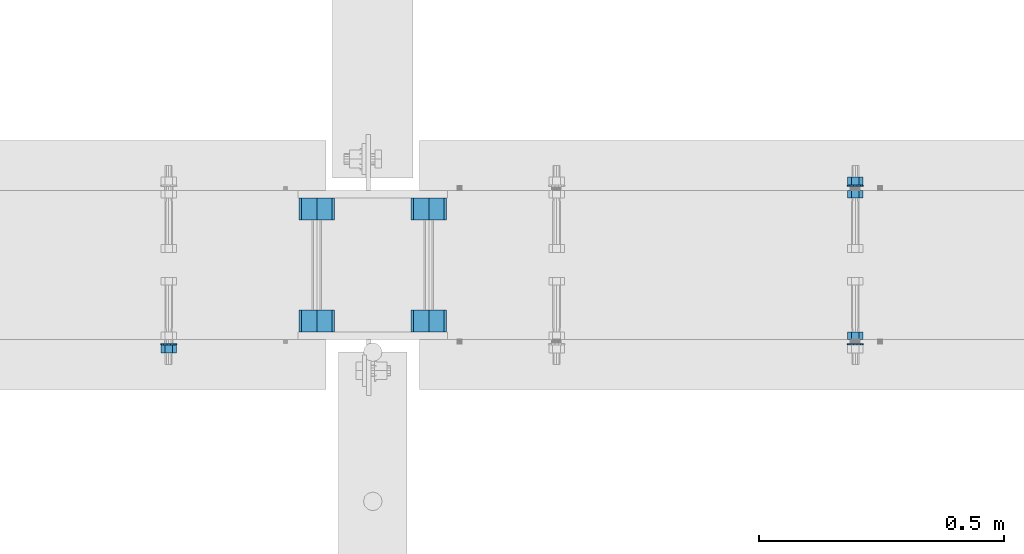
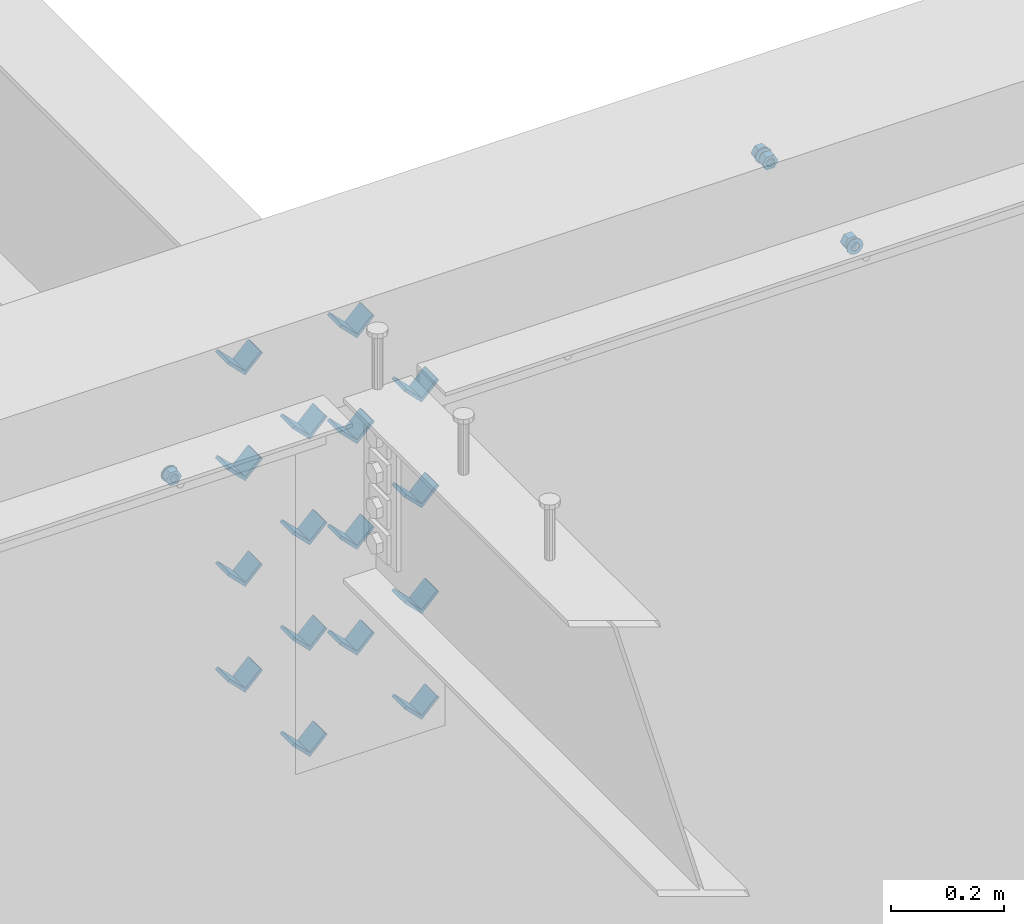
# One storey, part 604 of 975: 23 beams.
"""IFC2X3 building model written with IfcOpenShell, lengths in millimetres."""

from ifc_helpers import new_model, si_unit, frame, origin_with_axes, place, context, subcontext, project, spatial, faceted_brep, material, type_object, element, save


model = new_model("IFC2X3")

# Units and contexts
model_context = context("Model", 3, precision=1e-05, world=origin_with_axes())
body_context = subcontext(model_context, "Body", "Model", "MODEL_VIEW")
ifc_project = project(units=[si_unit("LENGTHUNIT", "METRE", prefix="MILLI"), si_unit("AREAUNIT", "SQUARE_METRE"), si_unit("VOLUMEUNIT", "CUBIC_METRE"), si_unit("MASSUNIT", "GRAM", prefix="KILO"), si_unit("TIMEUNIT", "SECOND"), si_unit("PLANEANGLEUNIT", "RADIAN"), si_unit("SOLIDANGLEUNIT", "STERADIAN"), si_unit("THERMODYNAMICTEMPERATUREUNIT", "DEGREE_CELSIUS"), si_unit("LUMINOUSINTENSITYUNIT", "LUMEN")], contexts=[model_context])

# Site, building, storey
site_placement = place(None, origin_with_axes())
site = spatial("IfcSite", under=ifc_project, at=site_placement, CompositionType="ELEMENT")
building_placement = place(site_placement, origin_with_axes())
building = spatial("IfcBuilding", under=site, at=building_placement, Name="Undefined", CompositionType="ELEMENT")
storey_placement = place(building_placement, origin_with_axes())
storey = spatial("IfcBuildingStorey", under=building, at=storey_placement, Name="Undefined", CompositionType="ELEMENT", Elevation=0.0)

# Beams
ifc_material = material(Name="STEEL/A36")
beam_type_1 = type_object("IfcBeamType", Name="L2X2X1/4", PredefinedType="NOTDEFINED")
for number, where, z_axis, x_axis, name in (
    (1, (4176.18387741957, 20459.6337290899, 3417.06996517217), (-0.707106781186557, 0.0, 0.707106781186538), (0.0, 1.0, 0.0), "ANGLE"),
    (2, (4404.78387741958, 20459.6337290899, 3417.06996517217), (-0.707106781186557, 0.0, 0.707106781186538), (0.0, 1.0, 0.0), "ANGLE"),
    (3, (4176.18387741957, 20688.3662709101, 3417.06996517217), (-0.707106781186557, 0.0, 0.707106781186538), (0.0, 1.0, 0.0), "ANGLE"),
    (4, (4404.78387741958, 20688.3662709101, 3417.06996517217), (-0.707106781186557, 0.0, 0.707106781186538), (0.0, 1.0, 0.0), "ANGLE"),
    (5, (4176.18387741957, 20459.6337290899, 3645.66996517217), (-0.707106781186557, 0.0, 0.707106781186538), (0.0, 1.0, 0.0), "ANGLE"),
    (6, (4404.78387741958, 20459.6337290899, 3645.66996517217), (-0.707106781186557, 0.0, 0.707106781186538), (0.0, 1.0, 0.0), "ANGLE"),
    (7, (4176.18387741957, 20688.3662709101, 3645.66996517217), (-0.707106781186557, 0.0, 0.707106781186538), (0.0, 1.0, 0.0), "ANGLE"),
    (8, (4404.78387741958, 20688.3662709101, 3645.66996517217), (-0.707106781186557, 0.0, 0.707106781186538), (0.0, 1.0, 0.0), "ANGLE"),
    (9, (4176.18387741845, 20459.6337290899, 3188.4699651707), (-0.707106781186557, 0.0, 0.707106781186538), (0.0, 1.0, 0.0), "ANGLE"),
    (10, (4176.18387741957, 20459.6337290899, 3874.26996517217), (-0.707106781186557, 0.0, 0.707106781186538), (0.0, 1.0, 0.0), "ANGLE"),
    (11, (4404.78387741845, 20459.6337290899, 3188.4699651707), (-0.707106781186557, 0.0, 0.707106781186538), (0.0, 1.0, 0.0), "ANGLE"),
    (12, (4404.78387741958, 20459.6337290899, 3874.26996517217), (-0.707106781186557, 0.0, 0.707106781186538), (0.0, 1.0, 0.0), "ANGLE"),
    (13, (4176.18387741845, 20688.3662709101, 3188.4699651707), (-0.707106781186557, 0.0, 0.707106781186538), (0.0, 1.0, 0.0), "ANGLE"),
    (14, (4176.18387741957, 20688.3662709101, 3874.26996517217), (-0.707106781186557, 0.0, 0.707106781186538), (0.0, 1.0, 0.0), "ANGLE"),
    (15, (4404.78387741845, 20688.3662709101, 3188.4699651707), (-0.707106781186557, 0.0, 0.707106781186538), (0.0, 1.0, 0.0), "ANGLE"),
    (16, (4404.78387741958, 20688.3662709101, 3874.26996517217), (-0.707106781186557, 0.0, 0.707106781186538), (0.0, 1.0, 0.0), "ANGLE"),
):
    element("IfcBeam", number, at=place(storey_placement, frame(where, z_axis=z_axis, x_axis=x_axis)), inside=storey, type_object=beam_type_1, material=ifc_material, Name=name, ObjectType="L2X2X1/4", context=body_context, shape_type="Brep", body=[
        faceted_brep([(0.0, 25.3999999999724, -25.4000000000342), (0.0, 25.400000000016, 25.4000000000196), (44.4499999999971, 25.4000000000033, 25.4000000000051), (44.4499999999971, 25.4000000000033, -25.4000000000024), (3.27418092638254e-11, 19.0500000000002, 25.4000000000269), (44.4499999999971, 19.0500000000011, 25.400000000006), (-2.5465851649642e-11, 19.0500000000002, -19.0500000000211), (44.4499999999971, 19.0500000000011, -19.050000000002), (-2.5465851649642e-11, -25.3999999999996, -19.0500000000211), (44.4499999999971, -25.4000000000069, -19.0500000000038), (0.0, -25.400000000016, -25.4000000000196), (44.4499999999971, -25.4000000000069, -25.4000000000033)], [[[0, 1, 2, 3]], [[1, 4, 5, 2]], [[4, 6, 7, 5]], [[6, 8, 9, 7]], [[8, 10, 11, 9]], [[10, 0, 3, 11]], [[5, 7, 9, 11, 3, 2]], [[10, 8, 6, 4, 1, 0]]]),
    ])
beam_type_2 = type_object("IfcBeamType", Name="5/8_HEAVY_HEX_NUT", PredefinedType="NOTDEFINED")
beam_1_placement = place(storey_placement, frame((5275.26259380676, 20443.825, 3886.2), z_axis=(0.0, 0.0, -1.0), x_axis=(0.0, 1.0, 0.0)))
element("IfcBeam", 17, at=beam_1_placement, inside=storey, type_object=beam_type_2, material=ifc_material, Name="NUT", ObjectType="5/8_HEAVY_HEX_NUT", context=body_context, shape_type="Brep", body=[
    faceted_brep([(-1.09139364212751e-11, -15.8800001144436, -2.72848410531878e-12), (1.45519152283669e-11, -7.94000005722046, -13.7500000000036), (15.8750000000146, -7.94000005722137, -13.7500000000045), (15.8749999999891, -15.8800001144446, -2.72848410531878e-12), (2.91038304567337e-11, 7.94000005722319, -13.7500000000027), (15.8750000000291, 7.94000005722319, -13.7500000000027), (2.18278728425503e-11, 15.8800001144436, 9.09494701772928e-13), (15.8750000000218, 15.8800001144427, 9.09494701772928e-13), (-7.27595761418343e-12, 7.94000005722046, 13.7500000000027), (15.8749999999927, 7.94000005722046, 13.7500000000027), (-2.18278728425503e-11, -7.94000005722228, 13.7500000000009), (15.8749999999782, -7.94000005722319, 13.7500000000009), (-7.27595761418343e-12, 0.0, 8.72999954223724), (0.0, 3.78780484388062, 7.86545780435881), (15.875, 3.78780484387971, 7.86545780435881), (15.8749999999927, -9.09494701772928e-13, 8.72999954223724), (7.27595761418343e-12, 6.82538848405238, 5.44306568481716), (15.8750000000073, 6.82538848405238, 5.44306568481716), (1.09139364212751e-11, 8.51112022706275, 1.94260765157742), (15.8750000000109, 8.51112022706093, 1.94260765157651), (1.45519152283669e-11, 8.51112022706184, -1.94260765157651), (15.8750000000146, 8.51112022706184, -1.94260765157651), (2.18278728425503e-11, 6.8253884840542, -5.44306568481716), (15.8750000000218, 6.82538848405238, -5.44306568481716), (1.81898940354586e-11, 3.78780484388153, -7.86545780435881), (15.8750000000182, 3.78780484388062, -7.86545780435881), (1.81898940354586e-11, 9.09494701772928e-13, -8.72999954223997), (15.8750000000182, 9.09494701772928e-13, -8.72999954223997), (1.09139364212751e-11, -3.78780484387971, -7.86545780436063), (15.8750000000109, -3.78780484388062, -7.86545780436063), (3.63797880709171e-12, -6.82538848405238, -5.44306568481807), (15.8750000000036, -6.82538848405329, -5.44306568481807), (0.0, -8.51112022706184, -1.94260765157833), (15.875, -8.51112022706184, -1.94260765157833), (-7.27595761418343e-12, -8.51112022706184, 1.9426076515756), (15.8749999999927, -8.51112022706275, 1.9426076515756), (-1.09139364212751e-11, -6.82538848405329, 5.44306568481534), (15.8749999999927, -6.8253884840542, 5.44306568481534), (-7.27595761418343e-12, -3.78780484388062, 7.8654578043579), (15.8749999999927, -3.78780484388153, 7.8654578043579)], [[[0, 1, 2, 3]], [[1, 4, 5, 2]], [[4, 6, 7, 5]], [[6, 8, 9, 7]], [[8, 10, 11, 9]], [[10, 0, 3, 11]], [[12, 13, 14, 15]], [[13, 16, 17, 14]], [[16, 18, 19, 17]], [[18, 20, 21, 19]], [[20, 22, 23, 21]], [[22, 24, 25, 23]], [[24, 26, 27, 25]], [[26, 28, 29, 27]], [[28, 30, 31, 29]], [[30, 32, 33, 31]], [[32, 34, 35, 33]], [[34, 36, 37, 35]], [[36, 38, 39, 37]], [[38, 12, 15, 39]], [[5, 7, 9, 11, 3, 2], [17, 19, 21, 23, 25, 27, 29, 31, 33, 35, 37, 39, 15, 14]], [[10, 8, 6, 4, 1, 0], [38, 36, 34, 32, 30, 28, 26, 24, 22, 20, 18, 16, 13, 12]]]),
])
beam_2_placement = place(storey_placement, frame((5275.26259380676, 20748.6249996637, 3886.2), z_axis=(0.0, 0.0, 1.0), x_axis=(0.0, -1.0, 0.0)))
element("IfcBeam", 18, at=beam_2_placement, inside=storey, type_object=beam_type_2, material=ifc_material, Name="NUT", ObjectType="5/8_HEAVY_HEX_NUT", context=body_context, shape_type="Brep", body=[
    faceted_brep([(-1.09139364212751e-11, -15.8800001144436, -2.72848410531878e-12), (1.45519152283669e-11, -7.94000005722046, -13.7500000000036), (15.8750000000146, -7.94000005722137, -13.7500000000045), (15.8749999999891, -15.8800001144446, -2.72848410531878e-12), (2.91038304567337e-11, 7.94000005722319, -13.7500000000027), (15.8750000000291, 7.94000005722319, -13.7500000000027), (2.18278728425503e-11, 15.8800001144436, 9.09494701772928e-13), (15.8750000000218, 15.8800001144427, 9.09494701772928e-13), (-7.27595761418343e-12, 7.94000005722046, 13.7500000000027), (15.8749999999927, 7.94000005722046, 13.7500000000027), (-2.18278728425503e-11, -7.94000005722228, 13.7500000000009), (15.8749999999782, -7.94000005722319, 13.7500000000009), (-7.27595761418343e-12, 0.0, 8.72999954223724), (0.0, 3.78780484388062, 7.86545780435881), (15.875, 3.78780484387971, 7.86545780435881), (15.8749999999927, -9.09494701772928e-13, 8.72999954223724), (7.27595761418343e-12, 6.82538848405238, 5.44306568481716), (15.8750000000073, 6.82538848405238, 5.44306568481716), (1.09139364212751e-11, 8.51112022706275, 1.94260765157742), (15.8750000000109, 8.51112022706093, 1.94260765157651), (1.45519152283669e-11, 8.51112022706184, -1.94260765157651), (15.8750000000146, 8.51112022706184, -1.94260765157651), (2.18278728425503e-11, 6.8253884840542, -5.44306568481716), (15.8750000000218, 6.82538848405238, -5.44306568481716), (1.81898940354586e-11, 3.78780484388153, -7.86545780435881), (15.8750000000182, 3.78780484388062, -7.86545780435881), (1.81898940354586e-11, 9.09494701772928e-13, -8.72999954223997), (15.8750000000182, 9.09494701772928e-13, -8.72999954223997), (1.09139364212751e-11, -3.78780484387971, -7.86545780436063), (15.8750000000109, -3.78780484388062, -7.86545780436063), (3.63797880709171e-12, -6.82538848405238, -5.44306568481807), (15.8750000000036, -6.82538848405329, -5.44306568481807), (0.0, -8.51112022706184, -1.94260765157833), (15.875, -8.51112022706184, -1.94260765157833), (-7.27595761418343e-12, -8.51112022706184, 1.9426076515756), (15.8749999999927, -8.51112022706275, 1.9426076515756), (-1.09139364212751e-11, -6.82538848405329, 5.44306568481534), (15.8749999999927, -6.8253884840542, 5.44306568481534), (-7.27595761418343e-12, -3.78780484388062, 7.8654578043579), (15.8749999999927, -3.78780484388153, 7.8654578043579)], [[[0, 1, 2, 3]], [[1, 4, 5, 2]], [[4, 6, 7, 5]], [[6, 8, 9, 7]], [[8, 10, 11, 9]], [[10, 0, 3, 11]], [[12, 13, 14, 15]], [[13, 16, 17, 14]], [[16, 18, 19, 17]], [[18, 20, 21, 19]], [[20, 22, 23, 21]], [[22, 24, 25, 23]], [[24, 26, 27, 25]], [[26, 28, 29, 27]], [[28, 30, 31, 29]], [[30, 32, 33, 31]], [[32, 34, 35, 33]], [[34, 36, 37, 35]], [[36, 38, 39, 37]], [[38, 12, 15, 39]], [[5, 7, 9, 11, 3, 2], [17, 19, 21, 23, 25, 27, 29, 31, 33, 35, 37, 39, 15, 14]], [[10, 8, 6, 4, 1, 0], [38, 36, 34, 32, 30, 28, 26, 24, 22, 20, 18, 16, 13, 12]]]),
])
beam_3_placement = place(storey_placement, frame((5275.26259380678, 20775.6125, 3886.2), z_axis=(0.0, 0.0, 1.0), x_axis=(0.0, -1.0, 0.0)))
element("IfcBeam", 19, at=beam_3_placement, inside=storey, type_object=beam_type_2, material=ifc_material, Name="NUT", ObjectType="5/8_HEAVY_HEX_NUT", context=body_context, shape_type="Brep", body=[
    faceted_brep([(-1.09139364212751e-11, -15.8800001144436, -2.72848410531878e-12), (1.45519152283669e-11, -7.94000005722046, -13.7500000000036), (15.8750000000146, -7.94000005722137, -13.7500000000045), (15.8749999999891, -15.8800001144446, -2.72848410531878e-12), (2.91038304567337e-11, 7.94000005722319, -13.7500000000027), (15.8750000000291, 7.94000005722319, -13.7500000000027), (2.18278728425503e-11, 15.8800001144436, 9.09494701772928e-13), (15.8750000000218, 15.8800001144427, 9.09494701772928e-13), (-7.27595761418343e-12, 7.94000005722046, 13.7500000000027), (15.8749999999927, 7.94000005722046, 13.7500000000027), (-2.18278728425503e-11, -7.94000005722228, 13.7500000000009), (15.8749999999782, -7.94000005722319, 13.7500000000009), (-7.27595761418343e-12, 0.0, 8.72999954223724), (0.0, 3.78780484388062, 7.86545780435881), (15.875, 3.78780484387971, 7.86545780435881), (15.8749999999927, -9.09494701772928e-13, 8.72999954223724), (7.27595761418343e-12, 6.82538848405238, 5.44306568481716), (15.8750000000073, 6.82538848405238, 5.44306568481716), (1.09139364212751e-11, 8.51112022706275, 1.94260765157742), (15.8750000000109, 8.51112022706093, 1.94260765157651), (1.45519152283669e-11, 8.51112022706184, -1.94260765157651), (15.8750000000146, 8.51112022706184, -1.94260765157651), (2.18278728425503e-11, 6.8253884840542, -5.44306568481716), (15.8750000000218, 6.82538848405238, -5.44306568481716), (1.81898940354586e-11, 3.78780484388153, -7.86545780435881), (15.8750000000182, 3.78780484388062, -7.86545780435881), (1.81898940354586e-11, 9.09494701772928e-13, -8.72999954223997), (15.8750000000182, 9.09494701772928e-13, -8.72999954223997), (1.09139364212751e-11, -3.78780484387971, -7.86545780436063), (15.8750000000109, -3.78780484388062, -7.86545780436063), (3.63797880709171e-12, -6.82538848405238, -5.44306568481807), (15.8750000000036, -6.82538848405329, -5.44306568481807), (0.0, -8.51112022706184, -1.94260765157833), (15.875, -8.51112022706184, -1.94260765157833), (-7.27595761418343e-12, -8.51112022706184, 1.9426076515756), (15.8749999999927, -8.51112022706275, 1.9426076515756), (-1.09139364212751e-11, -6.82538848405329, 5.44306568481534), (15.8749999999927, -6.8253884840542, 5.44306568481534), (-7.27595761418343e-12, -3.78780484388062, 7.8654578043579), (15.8749999999927, -3.78780484388153, 7.8654578043579)], [[[0, 1, 2, 3]], [[1, 4, 5, 2]], [[4, 6, 7, 5]], [[6, 8, 9, 7]], [[8, 10, 11, 9]], [[10, 0, 3, 11]], [[12, 13, 14, 15]], [[13, 16, 17, 14]], [[16, 18, 19, 17]], [[18, 20, 21, 19]], [[20, 22, 23, 21]], [[22, 24, 25, 23]], [[24, 26, 27, 25]], [[26, 28, 29, 27]], [[28, 30, 31, 29]], [[30, 32, 33, 31]], [[32, 34, 35, 33]], [[34, 36, 37, 35]], [[36, 38, 39, 37]], [[38, 12, 15, 39]], [[5, 7, 9, 11, 3, 2], [17, 19, 21, 23, 25, 27, 29, 31, 33, 35, 37, 39, 15, 14]], [[10, 8, 6, 4, 1, 0], [38, 36, 34, 32, 30, 28, 26, 24, 22, 20, 18, 16, 13, 12]]]),
])
beam_4_placement = place(storey_placement, frame((3874.02920478859, 20416.8375, 3886.2), z_axis=(0.0, 0.0, 1.0), x_axis=(0.0, 1.0, 0.0)))
element("IfcBeam", 20, at=beam_4_placement, inside=storey, type_object=beam_type_2, material=ifc_material, Name="NUT", ObjectType="5/8_HEAVY_HEX_NUT", context=body_context, shape_type="Brep", body=[
    faceted_brep([(-1.09139364212751e-11, -15.8800001144436, -2.72848410531878e-12), (1.45519152283669e-11, -7.94000005722046, -13.7500000000036), (15.8750000000146, -7.94000005722137, -13.7500000000045), (15.8749999999891, -15.8800001144446, -2.72848410531878e-12), (2.91038304567337e-11, 7.94000005722319, -13.7500000000027), (15.8750000000291, 7.94000005722319, -13.7500000000027), (2.18278728425503e-11, 15.8800001144436, 9.09494701772928e-13), (15.8750000000218, 15.8800001144427, 9.09494701772928e-13), (-7.27595761418343e-12, 7.94000005722046, 13.7500000000027), (15.8749999999927, 7.94000005722046, 13.7500000000027), (-2.18278728425503e-11, -7.94000005722228, 13.7500000000009), (15.8749999999782, -7.94000005722319, 13.7500000000009), (-7.27595761418343e-12, 0.0, 8.72999954223724), (0.0, 3.78780484388062, 7.86545780435881), (15.875, 3.78780484387971, 7.86545780435881), (15.8749999999927, -9.09494701772928e-13, 8.72999954223724), (7.27595761418343e-12, 6.82538848405238, 5.44306568481716), (15.8750000000073, 6.82538848405238, 5.44306568481716), (1.09139364212751e-11, 8.51112022706275, 1.94260765157742), (15.8750000000109, 8.51112022706093, 1.94260765157651), (1.45519152283669e-11, 8.51112022706184, -1.94260765157651), (15.8750000000146, 8.51112022706184, -1.94260765157651), (2.18278728425503e-11, 6.8253884840542, -5.44306568481716), (15.8750000000218, 6.82538848405238, -5.44306568481716), (1.81898940354586e-11, 3.78780484388153, -7.86545780435881), (15.8750000000182, 3.78780484388062, -7.86545780435881), (1.81898940354586e-11, 9.09494701772928e-13, -8.72999954223997), (15.8750000000182, 9.09494701772928e-13, -8.72999954223997), (1.09139364212751e-11, -3.78780484387971, -7.86545780436063), (15.8750000000109, -3.78780484388062, -7.86545780436063), (3.63797880709171e-12, -6.82538848405238, -5.44306568481807), (15.8750000000036, -6.82538848405329, -5.44306568481807), (0.0, -8.51112022706184, -1.94260765157833), (15.875, -8.51112022706184, -1.94260765157833), (-7.27595761418343e-12, -8.51112022706184, 1.9426076515756), (15.8749999999927, -8.51112022706275, 1.9426076515756), (-1.09139364212751e-11, -6.82538848405329, 5.44306568481534), (15.8749999999927, -6.8253884840542, 5.44306568481534), (-7.27595761418343e-12, -3.78780484388062, 7.8654578043579), (15.8749999999927, -3.78780484388153, 7.8654578043579)], [[[0, 1, 2, 3]], [[1, 4, 5, 2]], [[4, 6, 7, 5]], [[6, 8, 9, 7]], [[8, 10, 11, 9]], [[10, 0, 3, 11]], [[12, 13, 14, 15]], [[13, 16, 17, 14]], [[16, 18, 19, 17]], [[18, 20, 21, 19]], [[20, 22, 23, 21]], [[22, 24, 25, 23]], [[24, 26, 27, 25]], [[26, 28, 29, 27]], [[28, 30, 31, 29]], [[30, 32, 33, 31]], [[32, 34, 35, 33]], [[34, 36, 37, 35]], [[36, 38, 39, 37]], [[38, 12, 15, 39]], [[5, 7, 9, 11, 3, 2], [17, 19, 21, 23, 25, 27, 29, 31, 33, 35, 37, 39, 15, 14]], [[10, 8, 6, 4, 1, 0], [38, 36, 34, 32, 30, 28, 26, 24, 22, 20, 18, 16, 13, 12]]]),
])
beam_type_3 = type_object("IfcBeamType", Name="5/8_WASHER", PredefinedType="NOTDEFINED")
beam_5_placement = place(storey_placement, frame((5275.26259380682, 20759.7375, 3886.2), z_axis=(0.0, 0.0, 1.0), x_axis=(0.0, -1.0, 0.0)))
element("IfcBeam", 21, at=beam_5_placement, inside=storey, type_object=beam_type_3, material=ifc_material, Name="WASHER", ObjectType="5/8_WASHER", context=body_context, shape_type="Brep", body=[
    faceted_brep([(1.09139364212751e-11, -16.670000076293, -2.72848410531878e-12), (2.18278728425503e-11, -15.0191510966704, -7.23284196419536), (3.1750000000211, -15.0191510966711, -7.23284196419627), (3.17500000001019, -16.6700000762937, -1.81898940354586e-12), (2.91038304567337e-11, -10.3935750445523, -13.0331308723944), (3.17500000002838, -10.3935750445526, -13.0331308723953), (2.91038304567337e-11, -3.70942398602756, -16.2520483704566), (3.17500000002838, -3.70942398602779, -16.2520483704566), (2.5465851649642e-11, 3.70942398602961, -16.2520483704557), (3.17500000002474, 3.70942398602961, -16.2520483704566), (1.45519152283669e-11, 10.3935750445542, -13.0331308723935), (3.17500000001382, 10.3935750445537, -13.0331308723944), (0.0, 15.0191510966717, -7.23284196419354), (3.17499999999927, 15.0191510966713, -7.23284196419354), (-7.27595761418343e-12, 16.6700000762933, 0.0), (3.174999999992, 16.6700000762928, -9.09494701772928e-13), (-1.81898940354586e-11, 15.0191510966706, 7.23284196419354), (3.17499999998108, 15.0191510966704, 7.23284196419354), (-2.5465851649642e-11, 10.3935750445519, 13.0331308723926), (3.17499999997381, 10.3935750445517, 13.0331308723926), (-2.5465851649642e-11, 3.70942398602733, 16.2520483704538), (3.17499999997381, 3.7094239860271, 16.2520483704529), (-2.18278728425503e-11, -3.70942398602983, 16.2520483704529), (3.17499999997744, -3.70942398603006, 16.2520483704538), (-1.09139364212751e-11, -10.3935750445542, 13.0331308723908), (3.17499999998836, -10.3935750445544, 13.0331308723908), (0.0, -15.0191510966717, 7.23284196419172), (3.17499999999927, -15.019151096672, 7.23284196419081), (-7.27595761418343e-12, 0.0, 8.72999954223724), (0.0, 3.78780484388062, 7.86545780435881), (3.17499999998472, 3.78780484387903, 7.86545780435699), (3.17499999998836, -9.09494701772928e-13, 8.72999954223542), (7.27595761418343e-12, 6.82538848405238, 5.44306568481716), (3.17499999998836, 6.82538848405102, 5.44306568481534), (1.09139364212751e-11, 8.51112022706275, 1.94260765157742), (3.174999999992, 8.51112022705979, 1.94260765157651), (1.45519152283669e-11, 8.51112022706184, -1.94260765157651), (3.17499999999563, 8.51112022706025, -1.94260765157742), (2.18278728425503e-11, 6.8253884840542, -5.44306568481716), (3.17500000000655, 6.8253884840517, -5.44306568481807), (1.81898940354586e-11, 3.78780484388153, -7.86545780435881), (3.17500000001019, 3.78780484388017, -7.86545780435972), (1.81898940354586e-11, 9.09494701772928e-13, -8.72999954223997), (3.17500000001382, 6.82121026329696e-13, -8.72999954223997), (1.09139364212751e-11, -3.78780484387971, -7.86545780436063), (3.17500000001382, -3.78780484387994, -7.86545780436063), (3.63797880709171e-12, -6.82538848405238, -5.44306568481807), (3.17500000001019, -6.82538848405147, -5.44306568481898), (0.0, -8.51112022706184, -1.94260765157833), (3.17500000001019, -8.5111202270607, -1.94260765157924), (-7.27595761418343e-12, -8.51112022706184, 1.9426076515756), (3.17500000000291, -8.51112022706093, 1.94260765157469), (-1.09139364212751e-11, -6.82538848405329, 5.44306568481534), (3.17499999999563, -6.82538848405238, 5.44306568481534), (-7.27595761418343e-12, -3.78780484388062, 7.8654578043579), (3.174999999992, -3.78780484388085, 7.86545780435699)], [[[0, 1, 2, 3]], [[1, 4, 5, 2]], [[4, 6, 7, 5]], [[6, 8, 9, 7]], [[8, 10, 11, 9]], [[10, 12, 13, 11]], [[12, 14, 15, 13]], [[14, 16, 17, 15]], [[16, 18, 19, 17]], [[18, 20, 21, 19]], [[20, 22, 23, 21]], [[22, 24, 25, 23]], [[24, 26, 27, 25]], [[26, 0, 3, 27]], [[28, 29, 30, 31]], [[29, 32, 33, 30]], [[32, 34, 35, 33]], [[34, 36, 37, 35]], [[36, 38, 39, 37]], [[38, 40, 41, 39]], [[40, 42, 43, 41]], [[42, 44, 45, 43]], [[44, 46, 47, 45]], [[46, 48, 49, 47]], [[48, 50, 51, 49]], [[50, 52, 53, 51]], [[52, 54, 55, 53]], [[54, 28, 31, 55]], [[5, 7, 9, 11, 13, 15, 17, 19, 21, 23, 25, 27, 3, 2], [33, 35, 37, 39, 41, 43, 45, 47, 49, 51, 53, 55, 31, 30]], [[26, 24, 22, 20, 18, 16, 14, 12, 10, 8, 6, 4, 1, 0], [54, 52, 50, 48, 46, 44, 42, 40, 38, 36, 34, 32, 29, 28]]]),
])
beam_6_placement = place(storey_placement, frame((5275.26259380682, 20432.7125, 3886.2), z_axis=(0.0, 0.0, -1.0), x_axis=(0.0, 1.0, 0.0)))
element("IfcBeam", 22, at=beam_6_placement, inside=storey, type_object=beam_type_3, material=ifc_material, Name="WASHER", ObjectType="5/8_WASHER", context=body_context, shape_type="Brep", body=[
    faceted_brep([(1.09139364212751e-11, -16.670000076293, -2.72848410531878e-12), (2.18278728425503e-11, -15.0191510966704, -7.23284196419536), (3.1750000000211, -15.0191510966711, -7.23284196419627), (3.17500000001019, -16.6700000762937, -1.81898940354586e-12), (2.91038304567337e-11, -10.3935750445523, -13.0331308723944), (3.17500000002838, -10.3935750445526, -13.0331308723953), (2.91038304567337e-11, -3.70942398602756, -16.2520483704566), (3.17500000002838, -3.70942398602779, -16.2520483704566), (2.5465851649642e-11, 3.70942398602961, -16.2520483704557), (3.17500000002474, 3.70942398602961, -16.2520483704566), (1.45519152283669e-11, 10.3935750445542, -13.0331308723935), (3.17500000001382, 10.3935750445537, -13.0331308723944), (0.0, 15.0191510966717, -7.23284196419354), (3.17499999999927, 15.0191510966713, -7.23284196419354), (-7.27595761418343e-12, 16.6700000762933, 0.0), (3.174999999992, 16.6700000762928, -9.09494701772928e-13), (-1.81898940354586e-11, 15.0191510966706, 7.23284196419354), (3.17499999998108, 15.0191510966704, 7.23284196419354), (-2.5465851649642e-11, 10.3935750445519, 13.0331308723926), (3.17499999997381, 10.3935750445517, 13.0331308723926), (-2.5465851649642e-11, 3.70942398602733, 16.2520483704538), (3.17499999997381, 3.7094239860271, 16.2520483704529), (-2.18278728425503e-11, -3.70942398602983, 16.2520483704529), (3.17499999997744, -3.70942398603006, 16.2520483704538), (-1.09139364212751e-11, -10.3935750445542, 13.0331308723908), (3.17499999998836, -10.3935750445544, 13.0331308723908), (0.0, -15.0191510966717, 7.23284196419172), (3.17499999999927, -15.019151096672, 7.23284196419081), (-7.27595761418343e-12, 0.0, 8.72999954223724), (0.0, 3.78780484388062, 7.86545780435881), (3.17499999998472, 3.78780484387903, 7.86545780435699), (3.17499999998836, -9.09494701772928e-13, 8.72999954223542), (7.27595761418343e-12, 6.82538848405238, 5.44306568481716), (3.17499999998836, 6.82538848405102, 5.44306568481534), (1.09139364212751e-11, 8.51112022706275, 1.94260765157742), (3.174999999992, 8.51112022705979, 1.94260765157651), (1.45519152283669e-11, 8.51112022706184, -1.94260765157651), (3.17499999999563, 8.51112022706025, -1.94260765157742), (2.18278728425503e-11, 6.8253884840542, -5.44306568481716), (3.17500000000655, 6.8253884840517, -5.44306568481807), (1.81898940354586e-11, 3.78780484388153, -7.86545780435881), (3.17500000001019, 3.78780484388017, -7.86545780435972), (1.81898940354586e-11, 9.09494701772928e-13, -8.72999954223997), (3.17500000001382, 6.82121026329696e-13, -8.72999954223997), (1.09139364212751e-11, -3.78780484387971, -7.86545780436063), (3.17500000001382, -3.78780484387994, -7.86545780436063), (3.63797880709171e-12, -6.82538848405238, -5.44306568481807), (3.17500000001019, -6.82538848405147, -5.44306568481898), (0.0, -8.51112022706184, -1.94260765157833), (3.17500000001019, -8.5111202270607, -1.94260765157924), (-7.27595761418343e-12, -8.51112022706184, 1.9426076515756), (3.17500000000291, -8.51112022706093, 1.94260765157469), (-1.09139364212751e-11, -6.82538848405329, 5.44306568481534), (3.17499999999563, -6.82538848405238, 5.44306568481534), (-7.27595761418343e-12, -3.78780484388062, 7.8654578043579), (3.174999999992, -3.78780484388085, 7.86545780435699)], [[[0, 1, 2, 3]], [[1, 4, 5, 2]], [[4, 6, 7, 5]], [[6, 8, 9, 7]], [[8, 10, 11, 9]], [[10, 12, 13, 11]], [[12, 14, 15, 13]], [[14, 16, 17, 15]], [[16, 18, 19, 17]], [[18, 20, 21, 19]], [[20, 22, 23, 21]], [[22, 24, 25, 23]], [[24, 26, 27, 25]], [[26, 0, 3, 27]], [[28, 29, 30, 31]], [[29, 32, 33, 30]], [[32, 34, 35, 33]], [[34, 36, 37, 35]], [[36, 38, 39, 37]], [[38, 40, 41, 39]], [[40, 42, 43, 41]], [[42, 44, 45, 43]], [[44, 46, 47, 45]], [[46, 48, 49, 47]], [[48, 50, 51, 49]], [[50, 52, 53, 51]], [[52, 54, 55, 53]], [[54, 28, 31, 55]], [[5, 7, 9, 11, 13, 15, 17, 19, 21, 23, 25, 27, 3, 2], [33, 35, 37, 39, 41, 43, 45, 47, 49, 51, 53, 55, 31, 30]], [[26, 24, 22, 20, 18, 16, 14, 12, 10, 8, 6, 4, 1, 0], [54, 52, 50, 48, 46, 44, 42, 40, 38, 36, 34, 32, 29, 28]]]),
])
beam_7_placement = place(storey_placement, frame((3874.0292047886, 20432.7125, 3886.2), z_axis=(0.0, 0.0, 1.0), x_axis=(0.0, 1.0, 0.0)))
element("IfcBeam", 23, at=beam_7_placement, inside=storey, type_object=beam_type_3, material=ifc_material, Name="WASHER", ObjectType="5/8_WASHER", context=body_context, shape_type="Brep", body=[
    faceted_brep([(1.09139364212751e-11, -16.670000076293, -2.72848410531878e-12), (2.18278728425503e-11, -15.0191510966704, -7.23284196419536), (3.1750000000211, -15.0191510966711, -7.23284196419627), (3.17500000001019, -16.6700000762937, -1.81898940354586e-12), (2.91038304567337e-11, -10.3935750445523, -13.0331308723944), (3.17500000002838, -10.3935750445526, -13.0331308723953), (2.91038304567337e-11, -3.70942398602756, -16.2520483704566), (3.17500000002838, -3.70942398602779, -16.2520483704566), (2.5465851649642e-11, 3.70942398602961, -16.2520483704557), (3.17500000002474, 3.70942398602961, -16.2520483704566), (1.45519152283669e-11, 10.3935750445542, -13.0331308723935), (3.17500000001382, 10.3935750445537, -13.0331308723944), (0.0, 15.0191510966717, -7.23284196419354), (3.17499999999927, 15.0191510966713, -7.23284196419354), (-7.27595761418343e-12, 16.6700000762933, 0.0), (3.174999999992, 16.6700000762928, -9.09494701772928e-13), (-1.81898940354586e-11, 15.0191510966706, 7.23284196419354), (3.17499999998108, 15.0191510966704, 7.23284196419354), (-2.5465851649642e-11, 10.3935750445519, 13.0331308723926), (3.17499999997381, 10.3935750445517, 13.0331308723926), (-2.5465851649642e-11, 3.70942398602733, 16.2520483704538), (3.17499999997381, 3.7094239860271, 16.2520483704529), (-2.18278728425503e-11, -3.70942398602983, 16.2520483704529), (3.17499999997744, -3.70942398603006, 16.2520483704538), (-1.09139364212751e-11, -10.3935750445542, 13.0331308723908), (3.17499999998836, -10.3935750445544, 13.0331308723908), (0.0, -15.0191510966717, 7.23284196419172), (3.17499999999927, -15.019151096672, 7.23284196419081), (-7.27595761418343e-12, 0.0, 8.72999954223724), (0.0, 3.78780484388062, 7.86545780435881), (3.17499999998472, 3.78780484387903, 7.86545780435699), (3.17499999998836, -9.09494701772928e-13, 8.72999954223542), (7.27595761418343e-12, 6.82538848405238, 5.44306568481716), (3.17499999998836, 6.82538848405102, 5.44306568481534), (1.09139364212751e-11, 8.51112022706275, 1.94260765157742), (3.174999999992, 8.51112022705979, 1.94260765157651), (1.45519152283669e-11, 8.51112022706184, -1.94260765157651), (3.17499999999563, 8.51112022706025, -1.94260765157742), (2.18278728425503e-11, 6.8253884840542, -5.44306568481716), (3.17500000000655, 6.8253884840517, -5.44306568481807), (1.81898940354586e-11, 3.78780484388153, -7.86545780435881), (3.17500000001019, 3.78780484388017, -7.86545780435972), (1.81898940354586e-11, 9.09494701772928e-13, -8.72999954223997), (3.17500000001382, 6.82121026329696e-13, -8.72999954223997), (1.09139364212751e-11, -3.78780484387971, -7.86545780436063), (3.17500000001382, -3.78780484387994, -7.86545780436063), (3.63797880709171e-12, -6.82538848405238, -5.44306568481807), (3.17500000001019, -6.82538848405147, -5.44306568481898), (0.0, -8.51112022706184, -1.94260765157833), (3.17500000001019, -8.5111202270607, -1.94260765157924), (-7.27595761418343e-12, -8.51112022706184, 1.9426076515756), (3.17500000000291, -8.51112022706093, 1.94260765157469), (-1.09139364212751e-11, -6.82538848405329, 5.44306568481534), (3.17499999999563, -6.82538848405238, 5.44306568481534), (-7.27595761418343e-12, -3.78780484388062, 7.8654578043579), (3.174999999992, -3.78780484388085, 7.86545780435699)], [[[0, 1, 2, 3]], [[1, 4, 5, 2]], [[4, 6, 7, 5]], [[6, 8, 9, 7]], [[8, 10, 11, 9]], [[10, 12, 13, 11]], [[12, 14, 15, 13]], [[14, 16, 17, 15]], [[16, 18, 19, 17]], [[18, 20, 21, 19]], [[20, 22, 23, 21]], [[22, 24, 25, 23]], [[24, 26, 27, 25]], [[26, 0, 3, 27]], [[28, 29, 30, 31]], [[29, 32, 33, 30]], [[32, 34, 35, 33]], [[34, 36, 37, 35]], [[36, 38, 39, 37]], [[38, 40, 41, 39]], [[40, 42, 43, 41]], [[42, 44, 45, 43]], [[44, 46, 47, 45]], [[46, 48, 49, 47]], [[48, 50, 51, 49]], [[50, 52, 53, 51]], [[52, 54, 55, 53]], [[54, 28, 31, 55]], [[5, 7, 9, 11, 13, 15, 17, 19, 21, 23, 25, 27, 3, 2], [33, 35, 37, 39, 41, 43, 45, 47, 49, 51, 53, 55, 31, 30]], [[26, 24, 22, 20, 18, 16, 14, 12, 10, 8, 6, 4, 1, 0], [54, 52, 50, 48, 46, 44, 42, 40, 38, 36, 34, 32, 29, 28]]]),
])

save(model, "model.ifc")
